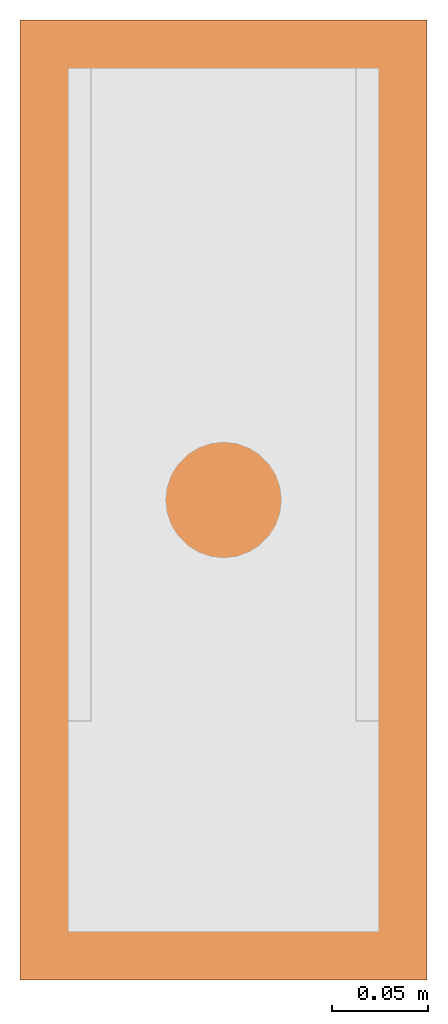
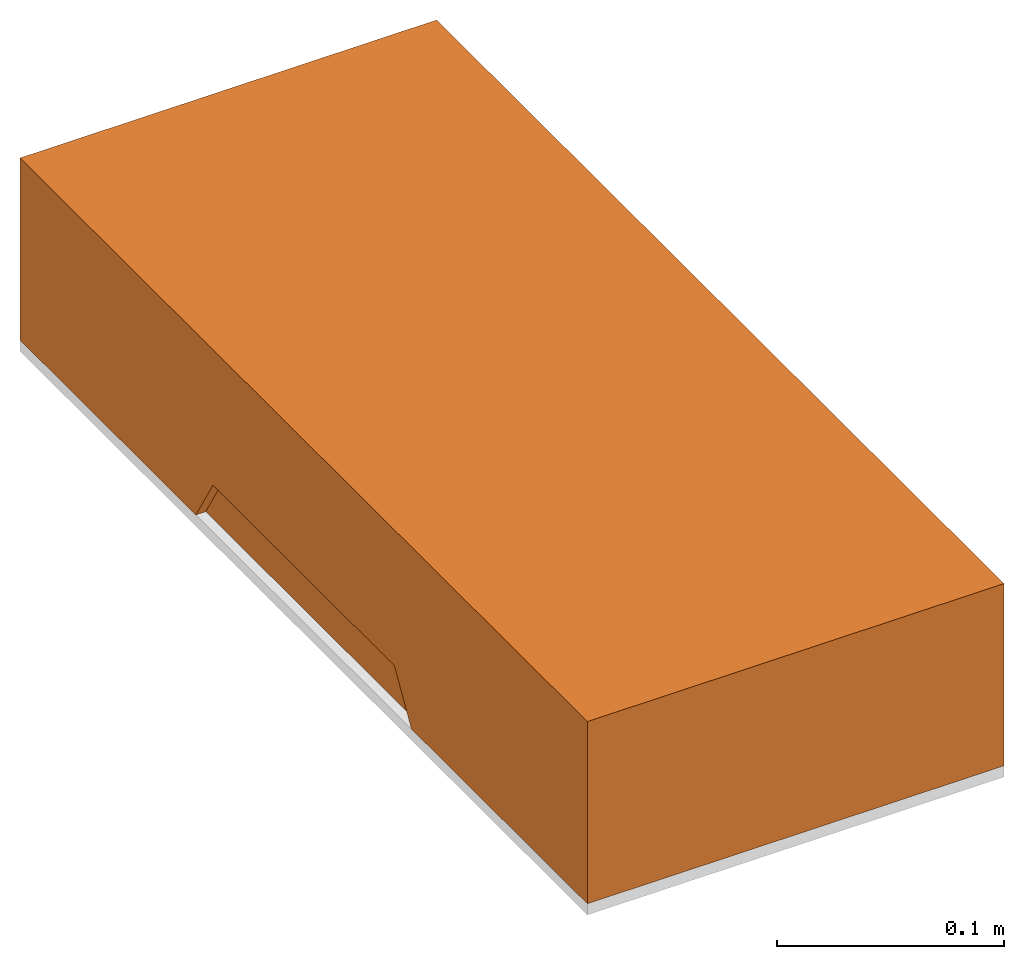
# One storey, part 2 of 2: 1 proxy.
"""IFC2X3 building model written with IfcOpenShell, lengths in millimetres."""

from ifc_helpers import new_model, si_unit, derived_unit, direction, origin_with_axes, place, context, project, spatial, faceted_brep, source, transform, mapped, element, save


model = new_model("IFC2X3")

# Units and contexts
model_context = context("Model", 3, precision=1e-05, world=origin_with_axes(), true_north=direction((0.0, 1.0, 0.0)))
ifc_project = project(units=[si_unit("LENGTHUNIT", "METRE", prefix="MILLI"), si_unit("AREAUNIT", "SQUARE_METRE"), si_unit("SOLIDANGLEUNIT", "STERADIAN"), si_unit("PLANEANGLEUNIT", "RADIAN"), si_unit("TIMEUNIT", "SECOND"), si_unit("THERMODYNAMICTEMPERATUREUNIT", "DEGREE_CELSIUS"), si_unit("LUMINOUSINTENSITYUNIT", "LUMEN"), si_unit("MASSUNIT", "GRAM", prefix="KILO"), si_unit("VOLUMEUNIT", "CUBIC_METRE"), derived_unit("MASSDENSITYUNIT", [(si_unit("MASSUNIT", "GRAM", prefix="KILO"), 0), (si_unit("VOLUMEUNIT", "CUBIC_METRE"), -1)])], contexts=[model_context])

# Site, building, storey
site_placement = place(None, origin_with_axes())
site = spatial("IfcSite", under=ifc_project, at=site_placement, CompositionType="ELEMENT")
building_placement = place(site_placement, origin_with_axes())
building = spatial("IfcBuilding", under=site, at=building_placement, Name="Default Building", CompositionType="ELEMENT")
storey_placement = place(building_placement, origin_with_axes())
storey = spatial("IfcBuildingStorey", under=building, at=storey_placement, Name="Default Storey", CompositionType="ELEMENT")

# Proxy
shared_shape = source(origin_with_axes(), model_context, "Body", "Brep", [
    faceted_brep([(106.0, 500.0, 0.0), (-106.0, 0.0, 0.0), (-106.0, 500.0, 0.0), (106.0, 0.0, 0.0), (45.0, 500.0, -98.0), (45.0, 495.0, -98.0), (-45.0, 495.0, -98.0), (-45.0, 500.0, -98.0), (-106.0, 500.0, -98.0), (-106.0, 345.0, -98.0), (-101.0, 345.0, -98.0), (-101.0, 154.99999999999994, -98.0), (-106.0, 154.99999999999994, -98.0), (-106.0, 0.0, -98.0), (106.0, 0.0, -98.0), (106.0, 154.99999999999994, -98.0), (101.0, 154.99999999999994, -98.0), (101.0, 345.0, -98.0), (106.0, 345.0, -98.0), (106.0, 500.0, -98.0), (-45.0, 485.0, -98.0), (-45.0, 475.0, -98.0), (-81.0, 475.0, -98.0), (-81.0, 345.0, -98.0), (-91.0, 345.0, -98.0), (-91.0, 154.99999999999994, -98.0), (-81.0, 154.99999999999994, -98.0), (-81.0, 25.0, -98.0), (81.0, 25.0, -98.0), (81.0, 154.99999999999994, -98.0), (91.0, 154.99999999999994, -98.0), (91.0, 345.0, -98.0), (81.0, 345.0, -98.0), (81.0, 475.0, -98.0), (45.0, 475.0, -98.0), (45.0, 485.0, -98.0), (-106.0, 330.0, -73.0), (-106.0, 170.0, -73.0), (106.0, 170.0, -73.0), (106.0, 330.0, -73.0), (32.5, 500.0, -73.0), (-32.5, 500.0, -73.0), (81.0, 25.0, -25.0), (-81.0, 475.0, -25.0), (-81.0, 25.0, -25.0), (81.0, 475.0, -25.0), (-81.0, 170.0, -73.0), (-81.0, 330.0, -73.0), (81.0, 330.0, -73.0), (81.0, 170.0, -73.0), (-32.5, 475.0, -73.0), (32.5, 475.0, -73.0), (-101.0, 330.0, -73.0), (-91.0, 330.0, -73.0), (91.0, 330.0, -73.0), (101.0, 330.0, -73.0), (-101.0, 170.0, -73.0), (-91.0, 170.0, -73.0), (91.0, 170.0, -73.0), (101.0, 170.0, -73.0), (-32.5, 485.0, -73.0), (-32.5, 495.0, -73.0), (32.5, 485.0, -73.0), (32.5, 495.0, -73.0)], [[[0, 1, 2]], [[1, 0, 3]], [[4, 5, 6, 7, 8, 9, 10, 11, 12, 13, 14, 15, 16, 17, 18, 19], [20, 21, 22, 23, 24, 25, 26, 27, 28, 29, 30, 31, 32, 33, 34, 35]], [[36, 9, 2]], [[37, 36, 2]], [[13, 12, 37]], [[13, 37, 2]], [[13, 2, 1]], [[2, 9, 8]], [[14, 1, 3]], [[1, 14, 13]], [[38, 15, 3]], [[39, 38, 3]], [[19, 18, 39]], [[19, 39, 3]], [[19, 3, 0]], [[3, 15, 14]], [[40, 4, 0]], [[41, 40, 0]], [[8, 7, 41]], [[8, 41, 0]], [[8, 0, 2]], [[0, 4, 19]], [[42, 43, 44]], [[43, 42, 45]], [[44, 26, 27]], [[46, 26, 44]], [[47, 46, 44]], [[22, 23, 47]], [[43, 22, 47]], [[47, 44, 43]], [[42, 27, 28]], [[27, 42, 44]], [[45, 32, 33]], [[48, 32, 45]], [[49, 48, 45]], [[28, 29, 49]], [[42, 28, 49]], [[49, 45, 42]], [[43, 21, 22]], [[50, 21, 43]], [[51, 50, 43]], [[33, 34, 51]], [[45, 33, 51]], [[51, 43, 45]], [[36, 10, 9]], [[10, 36, 52]], [[53, 23, 24]], [[23, 53, 47]], [[48, 31, 32]], [[31, 48, 54]], [[55, 18, 17]], [[18, 55, 39]], [[37, 52, 36]], [[52, 37, 56]], [[57, 47, 53]], [[47, 57, 46]], [[49, 54, 48]], [[54, 49, 58]], [[59, 39, 55]], [[39, 59, 38]], [[12, 56, 37]], [[56, 12, 11]], [[25, 46, 57]], [[46, 25, 26]], [[29, 58, 49]], [[58, 29, 30]], [[16, 38, 59]], [[38, 16, 15]], [[60, 21, 50]], [[21, 60, 20]], [[41, 6, 61]], [[6, 41, 7]], [[62, 50, 51]], [[50, 62, 60]], [[40, 61, 63]], [[61, 40, 41]], [[35, 51, 34]], [[51, 35, 62]], [[4, 63, 5]], [[63, 4, 40]], [[59, 55, 17]], [[59, 17, 16]], [[54, 58, 30]], [[54, 30, 31]], [[57, 53, 24]], [[57, 24, 25]], [[52, 56, 11]], [[52, 11, 10]], [[60, 62, 35]], [[60, 35, 20]], [[63, 61, 6]], [[63, 6, 5]]]),
])
proxy_placement = place(storey_placement, origin_with_axes())
element("IfcBuildingElementProxy", 1, at=proxy_placement, inside=storey, ObjectType="General", context=model_context, shape_type="MappedRepresentation", body=[
    mapped(shared_shape, transform((0.0, 0.0, 0.0), scale=1.0)),
])

save(model, "model.ifc")
